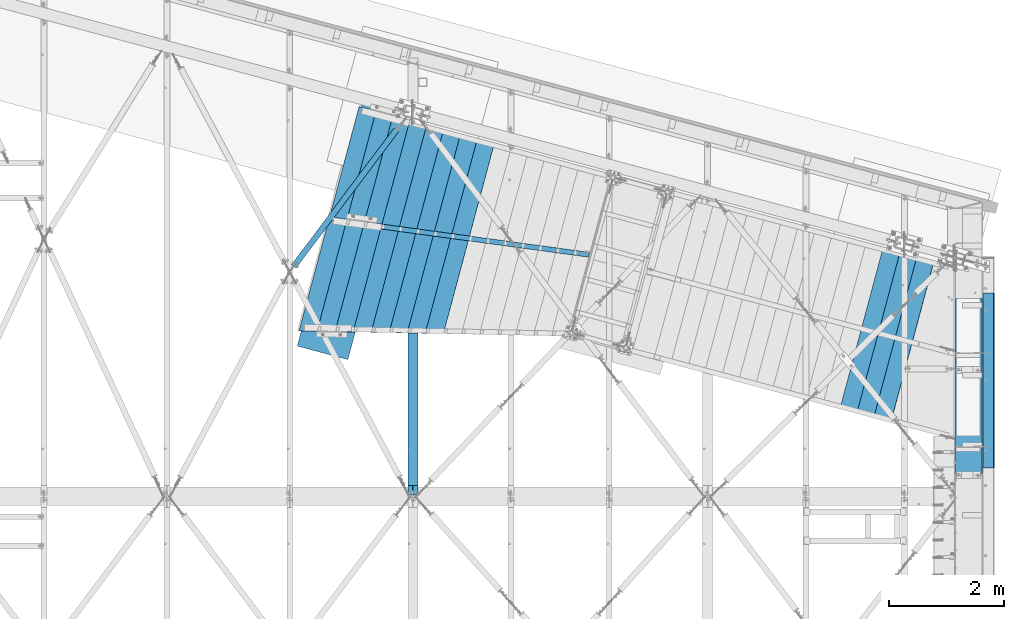
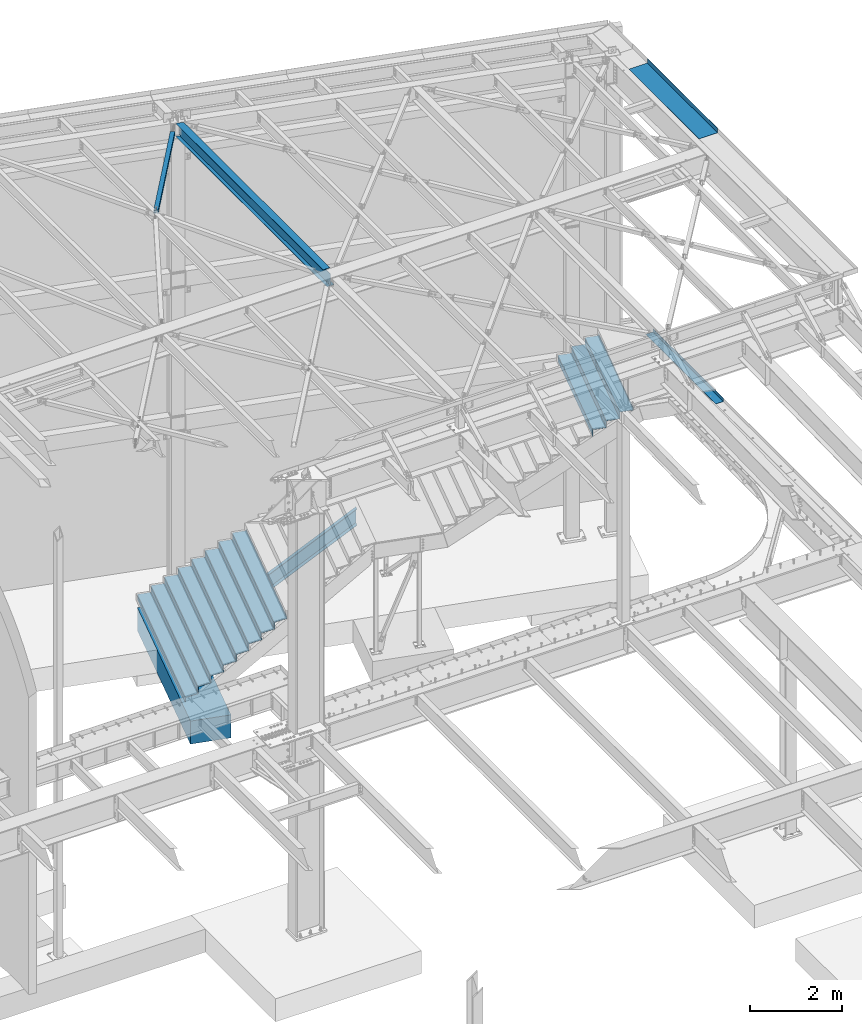
# One storey, part 1171 of 1763: 16 beams, 1 member, 7 elements without a shape of their own.
"""IFC2X3 building model written with IfcOpenShell, lengths in millimetres."""

from ifc_helpers import new_model, si_unit, frame, origin_with_axes, place, context, subcontext, project, spatial, faceted_brep, material, type_object, element, aggregate, save


model = new_model("IFC2X3")

# Units and contexts
model_context = context("Model", 3, precision=1e-05, world=origin_with_axes())
body_context = subcontext(model_context, "Body", "Model", "MODEL_VIEW")
ifc_project = project(units=[si_unit("LENGTHUNIT", "METRE", prefix="MILLI"), si_unit("AREAUNIT", "SQUARE_METRE"), si_unit("VOLUMEUNIT", "CUBIC_METRE"), si_unit("MASSUNIT", "GRAM", prefix="KILO"), si_unit("TIMEUNIT", "SECOND"), si_unit("PLANEANGLEUNIT", "RADIAN"), si_unit("SOLIDANGLEUNIT", "STERADIAN"), si_unit("THERMODYNAMICTEMPERATUREUNIT", "DEGREE_CELSIUS"), si_unit("LUMINOUSINTENSITYUNIT", "LUMEN")], contexts=[model_context])

# Site, building, storey
site_placement = place(None, origin_with_axes())
site = spatial("IfcSite", under=ifc_project, at=site_placement, CompositionType="ELEMENT")
building_placement = place(site_placement, origin_with_axes())
building = spatial("IfcBuilding", under=site, at=building_placement, Name="Undefined", CompositionType="ELEMENT")
storey_placement = place(building_placement, origin_with_axes())
storey = spatial("IfcBuildingStorey", under=building, at=storey_placement, Name="Undefined", CompositionType="ELEMENT", Elevation=0.0)

# Assembly, beam
assembly_1_placement = place(storey_placement, origin_with_axes())
assembly_1 = element("IfcElementAssembly", 1, at=assembly_1_placement, inside=storey, Name="BEAM", AssemblyPlace="NOTDEFINED", PredefinedType="RIGID_FRAME")
ifc_material_1 = material(Name="STEEL/A992")
beam_type_1 = type_object("IfcBeamType", Name="W14X30", PredefinedType="NOTDEFINED")
beam_1_placement = place(assembly_1_placement, frame((-31109.3096174484, 57702.4500000007, 12269.7875), z_axis=(0.0, 0.0, 1.0), x_axis=(0.0, 1.0, 0.0)))
beam_1 = element("IfcBeam", 2, at=beam_1_placement, type_object=beam_type_1, material=ifc_material_1, Name="BEAM", ObjectType="W14X30", context=body_context, shape_type="Brep", body=[
    faceted_brep([(6565.47208704926, 3.17499999999927, -166.6875), (6545.74981877552, 3.17499999999927, -166.6875), (6544.04801117296, -3.17499999999927, -166.6875), (6563.7702794467, -3.17499999999927, -166.6875), (6529.72406312962, 3.17499999999927, -155.679724431486), (6528.02225552706, -3.17499999999927, -155.679724427036), (6526.36654579163, 3.17499999999927, -152.226204529208), (6524.66473818907, -3.17499999999927, -152.226204524761), (6525.14678965067, 3.17499999999927, -147.637500862207), (6523.44498204811, -3.17499999999927, -147.637500857758), (6526.36654603869, 3.17499999999927, -143.048797256899), (6524.66473843613, -3.17499999999927, -143.048797252452), (6529.72406356262, 3.17499999999927, -139.595277524442), (6528.02225596006, -3.17499999999927, -139.595277519993), (6535.00792532179, 3.17499999999927, -138.112501016223), (6533.30611771923, -3.17499999999927, -138.112501011774), (6567.87837071862, 3.17499999999927, -138.11250011349), (6566.17656311606, -3.17499999999927, -138.112500109051), (192.087499999572, 85.7249999999985, 176.2125), (192.087499999572, -85.7249999999985, 176.2125), (6541.64678061339, -85.7249999999985, 176.2125), (6587.59558588255, 85.7249999999985, 176.2125), (6567.87331845542, 85.7249999999985, 166.6875), (192.087499999572, 85.7249999999985, 166.6875), (6593.28891422421, 85.7249999999985, 166.6875), (6545.74981962212, 3.17499999999927, 166.6875), (192.087499999572, 3.17499999999927, 166.6875), (6571.1654153411, 3.17500001334702, 166.687500583917), (20.6374999995751, 85.7249999999985, -176.2125), (20.6374999995751, 85.7249999999985, -166.6875), (6567.87331760882, 85.7249999999985, -166.6875), (6587.59558588256, 85.7249999999985, -166.6875), (6593.2889142238, 85.7249999984415, -176.21249961853), (20.6374999995751, -85.7249999999985, -176.2125), (6547.34010894869, -85.7249999999985, -176.2125), (20.6374999995751, -85.7249999999985, -166.6875), (6541.6467806134, -85.7249999999985, -166.6875), (20.6374999995751, 3.17499999999927, -166.6875), (20.6374999995751, -3.17499999999927, -166.6875), (20.6374999995751, -3.17499999999927, 137.852501678466), (20.6374999995751, 3.17499999999927, 137.852501678466), (179.387500190307, -3.17499999999927, 137.852501678466), (179.387500190307, 3.17499999999927, 137.852501678466), (184.247579708353, -3.17499999999927, 138.819231601054), (184.247579708353, 3.17499999999927, 138.819231601054), (188.367756176507, -3.17499999999927, 141.572245501531), (188.367756176507, 3.17499999999927, 141.572245501531), (191.120770076981, -3.17499999999927, 145.692421969685), (191.120770076981, 3.17499999999927, 145.692421969685), (192.087499999572, -3.17499999999927, 150.552501487731), (192.087499999572, 3.17499999999927, 150.552501487731), (192.087499999572, -3.17499999999927, 166.6875), (192.087499999572, -85.7249999999985, 166.6875), (6547.34010895504, -85.7249999999985, 166.6875), (6552.64892557845, -65.9160712421944, 166.6875), (6569.46360778834, -3.17499999999927, 166.6875), (6544.04801201956, -3.17499999999927, 166.6875), (6528.02225637366, -3.17499999999927, 155.679724224736), (6529.72406397622, 3.17499999999927, 155.679724229183), (6524.66473903567, -3.17499999999927, 152.226204322458), (6526.36654663823, 3.17499999999927, 152.226204326907), (6523.44498289471, -3.17499999999927, 147.637500655457), (6525.14679049727, 3.17499999999927, 147.637500659905), (6524.66473928273, -3.17499999999927, 143.048797050149), (6526.36654688529, 3.17499999999927, 143.048797054596), (6528.02225680666, -3.17499999999927, 139.595277317692), (6529.72406440922, 3.17499999999927, 139.59527732214), (6533.30611856584, -3.17499999999927, 138.112500809471), (6535.00792616839, 3.17499999999927, 138.112500813921), (6566.17656311627, -3.17499999999927, 138.112499906796), (6567.87837071883, 3.17499999999927, 138.112500230807), (6556.74970438206, -29.3710585869703, -166.6875)], [[[0, 1, 2, 3]], [[4, 5, 2, 1]], [[6, 7, 5, 4]], [[8, 9, 7, 6]], [[10, 11, 9, 8]], [[12, 13, 11, 10]], [[14, 15, 13, 12]], [[16, 17, 15, 14]], [[18, 19, 20, 21]], [[22, 23, 18, 21, 24]], [[25, 26, 23, 22, 24, 27]], [[28, 29, 30, 31, 32]], [[33, 28, 32, 34]], [[35, 33, 34, 36]], [[37, 29, 28, 33, 35, 38, 39, 40]], [[41, 42, 40, 39]], [[43, 44, 42, 41]], [[45, 46, 44, 43]], [[47, 48, 46, 45]], [[49, 50, 48, 47]], [[19, 18, 23, 26, 50, 49, 51, 52]], [[19, 52, 53, 20]], [[24, 21, 20, 53, 54, 55, 27]], [[53, 52, 51, 56, 55, 54]], [[27, 55, 56, 25]], [[25, 56, 57, 58]], [[58, 57, 59, 60]], [[60, 59, 61, 62]], [[62, 61, 63, 64]], [[64, 63, 65, 66]], [[66, 65, 67, 68]], [[68, 67, 69, 70]], [[12, 10, 8, 6, 4, 1, 37, 40, 42, 44, 46, 48, 50, 26, 25, 58, 60, 62, 64, 66, 68, 70, 16, 14]], [[30, 29, 37, 1, 0, 31]], [[71, 36, 34, 32, 31, 0, 3]], [[3, 2, 38, 35, 36, 71]], [[69, 67, 65, 63, 61, 59, 57, 56, 51, 49, 47, 45, 43, 41, 39, 38, 2, 5, 7, 9, 11, 13, 15, 17]], [[70, 69, 17, 16]]]),
])
aggregate(assembly_1, [beam_1])

assembly_2_placement = place(storey_placement, origin_with_axes())
assembly_2 = element("IfcElementAssembly", 3, at=assembly_2_placement, inside=storey, Name="H. BRACE", AssemblyPlace="NOTDEFINED", PredefinedType="RIGID_FRAME")
ifc_material_2 = material()
beam_type_2 = type_object("IfcBeamType", Name="HSS4X4X3/8", PredefinedType="NOTDEFINED")
beam_2_placement = place(assembly_2_placement, frame((-33252.4396171231, 61613.3086276461, 12371.3875), z_axis=(0.0, 0.0, 1.0), x_axis=(0.600727201865072, 0.799454081820439, 0.0)))
beam_2 = element("IfcBeam", 4, at=beam_2_placement, type_object=beam_type_2, material=ifc_material_2, Name="H. BRACE", ObjectType="HSS4X4X3/8", context=body_context, shape_type="Brep", body=[
    faceted_brep([(115.172522804187, 6.34475693275454, 50.7999999999993), (115.172522804187, 6.34475693275454, 41.2749999999996), (192.590787124383, 6.34474658969702, 41.2749999999996), (192.590787124383, 6.34474658969702, 50.7999999999993), (192.590785427663, -6.35525341022003, 50.7999999999993), (192.590785427663, -6.35525341022003, 41.2749999999996), (115.172522804187, -6.35524306716979, 41.2749999999996), (115.172522804187, -6.35524306716979, 50.7999999999993), (115.172522804187, 6.34475693275454, -41.2749999999996), (115.172522804187, 6.34475693275454, -50.7999999999993), (192.590787124383, 6.34474658969702, -50.7999999999993), (192.590787124383, 6.34474658969702, -41.2749999999996), (192.590785427663, -6.35525341022003, -41.2749999999996), (192.590785427663, -6.35525341022003, -50.7999999999993), (115.172522804187, -6.35524306716979, -50.7999999999993), (115.172522804187, -6.35524306716979, -41.2749999999996), (115.172522804194, -41.2749999996449, -41.2749999999996), (115.172522804194, -41.2749999996449, 41.2749999999996), (3100.13752571221, -41.2749999951629, 41.2749999999996), (3100.13752571221, -41.2749999951629, -41.2749999999996), (115.172522804183, 50.7999999999738, -50.7999999999993), (3100.13752571221, 50.8000000044631, -50.7999999999993), (3100.13752571221, -50.799999995128, -50.7999999999993), (115.172522804194, -50.79999999961, -50.7999999999993), (115.172522804194, -50.79999999961, 50.7999999999993), (3100.13752571221, -50.799999995128, 50.7999999999993), (115.172522804187, 41.2750000000087, 41.2749999999996), (3100.13752571221, 41.2750000045053, 41.2749999999996), (115.172522804187, 41.2750000000087, -41.2749999999996), (3100.13752571221, 41.2750000045053, -41.2749999999996), (3100.13752571221, 50.8000000044631, 50.7999999999993), (115.172522804183, 50.7999999999738, 50.7999999999993)], [[[0, 1, 2, 3]], [[4, 5, 6, 7]], [[3, 2, 5, 4]], [[8, 9, 10, 11]], [[12, 13, 14, 15]], [[11, 10, 13, 12]], [[16, 17, 18, 19]], [[9, 20, 21, 22, 23, 14, 13, 10]], [[24, 23, 22, 25]], [[17, 16, 15, 14, 23, 24, 7, 6]], [[1, 26, 27, 18, 17, 6, 5, 2]], [[26, 28, 29, 27]], [[25, 22, 21, 30], [18, 27, 29, 19]], [[20, 31, 30, 21]], [[24, 25, 30, 31, 0, 3, 4, 7]], [[31, 20, 9, 8, 28, 26, 1, 0]], [[16, 19, 29, 28, 8, 11, 12, 15]]]),
])
aggregate(assembly_2, [beam_2])

assembly_3_placement = place(storey_placement, origin_with_axes())
assembly_3 = element("IfcElementAssembly", 5, at=assembly_3_placement, inside=storey, Name="BEAM", AssemblyPlace="NOTDEFINED", PredefinedType="RIGID_FRAME")
ifc_material_3 = material(Name="STEEL/A36")
beam_type_3 = type_object("IfcBeamType", PredefinedType="NOTDEFINED")
beam_3_placement = place(assembly_3_placement, frame((-21657.3396174483, 59620.15, 12449.175), z_axis=(0.0, -1.0, 0.0), x_axis=(1.0, 0.0, 0.0)))
beam_3 = element("IfcBeam", 6, at=beam_3_placement, type_object=beam_type_3, material=ifc_material_3, Name="BENT_PLATE", context=body_context, shape_type="Brep", body=[
    faceted_brep([(0.0, -3.17499999999927, -1523.99999999999), (0.0, -3.17499999999927, 1524.0), (0.0, 3.17499999999927, 1524.0), (0.0, 3.17499999999927, -1523.99999999999), (460.375006103517, 3.17499999999927, 1524.0), (460.375006103517, 3.17499999999927, -1524.0), (466.725006103516, -3.17499999999927, -1524.0), (466.725006103516, -3.17499999999927, 1524.0), (460.375006103517, 123.825000000001, 1524.0), (460.375006103517, 123.825000000001, -1524.0), (466.725006103516, 123.825000000001, 1524.0), (466.725006103516, 123.825000000001, -1524.0)], [[[0, 1, 2, 3]], [[3, 2, 4, 5]], [[1, 0, 6, 7]], [[5, 4, 8, 9]], [[4, 2, 1, 7, 10, 8]], [[7, 6, 11, 10]], [[6, 0, 3, 5, 9, 11]], [[10, 11, 9, 8]]]),
])
aggregate(assembly_3, [beam_3])

# Assembly, member
assembly_4_placement = place(storey_placement, origin_with_axes())
assembly_4 = element("IfcElementAssembly", 7, at=assembly_4_placement, inside=storey, Name="STRINGER", AssemblyPlace="NOTDEFINED", PredefinedType="RIGID_FRAME")
member_type = type_object("IfcMemberType", Name="C15X33.9", PredefinedType="NOTDEFINED")
member_placement = place(assembly_4_placement, frame((-27854.1075451843, 61883.1673124353, 2495.92782182921), z_axis=(0.49628907329289, -0.0674194660398061, -0.865535540188265), x_axis=(-0.857644272703664, 0.116610785959708, -0.500847507826946)))
member = element("IfcMember", 8, at=member_placement, type_object=member_type, material=ifc_material_3, Name="STRINGER", ObjectType="C15X33.9", context=body_context, shape_type="Brep", body=[
    faceted_brep([(117.188553758227, -42.8624999999302, -190.499999999982), (122.242523850124, -42.8624999999083, -181.765892499978), (118.370424609493, 33.3374999998414, -169.070972499943), (314.035439820684, 33.3375000004671, 169.07097250022), (332.599308311685, -42.8624999992462, 181.7658925002), (337.653278403573, -42.8624999992244, 190.5000000002), (325.03304655453, 42.8625000004686, 190.500000000236), (104.568321909188, 42.8624999997701, -190.499999999949), (5293.38068464317, -42.8624999935782, -190.499999997053), (5278.29161672973, -42.8624999935855, -181.76589249706), (5256.36493450026, 33.3375000061424, -169.070972497037), (4672.18998903655, 33.3375000058222, 169.070972502683), (4650.25311450638, -42.862499993942, 181.765892502644), (4635.16404659294, -42.8624999939566, 190.500000002634), (4635.16977976208, 42.8625000057655, 190.50000000267), (5293.38641781232, 42.8625000061365, -190.499999997017)], [[[0, 1, 2, 3, 4, 5, 6, 7]], [[1, 0, 8, 9]], [[2, 1, 9, 10]], [[3, 2, 10, 11]], [[4, 3, 11, 12]], [[5, 4, 12, 13]], [[6, 5, 13, 14]], [[7, 6, 14, 15]], [[0, 7, 15, 8]], [[14, 13, 12, 11, 10, 9, 8, 15]]]),
])

# Assembly, beam
assembly_5_placement = place(storey_placement, origin_with_axes())
assembly_5 = element("IfcElementAssembly", 9, at=assembly_5_placement, inside=storey, Name="BEAM", AssemblyPlace="NOTDEFINED", PredefinedType="RIGID_FRAME")
beam_type_4 = type_object("IfcBeamType", PredefinedType="NOTDEFINED")
beam_4_placement = place(assembly_5_placement, frame((-21181.0896174484, 59717.781, 5199.0625), z_axis=(0.0, -1.0, 0.0), x_axis=(1.0, 0.0, 0.0)))
beam_4 = element("IfcBeam", 10, at=beam_4_placement, type_object=beam_type_4, material=ifc_material_3, Name="BENT PLATE", context=body_context, shape_type="Brep", body=[
    faceted_brep([(0.0, -4.76249999999982, -1524.0), (0.0, -4.76249999999982, 1524.0), (0.0, 4.76249999999982, 1524.0), (0.0, 4.76249999999982, -1524.0), (187.325021362303, 4.76249999999982, 1524.0), (187.325021362303, 4.76249999999982, -1524.0), (196.850021362305, -4.76249999999982, -1524.0), (196.850021362305, -4.76249999999982, 1524.0), (187.325021362303, 84.1374938964846, 1524.0), (187.325021362303, 84.1374938964846, -1524.0), (196.850021362305, 84.1374938964846, 1524.0), (196.850021362305, 84.1374938964846, -1524.0)], [[[0, 1, 2, 3]], [[3, 2, 4, 5]], [[1, 0, 6, 7]], [[5, 4, 8, 9]], [[4, 2, 1, 7, 10, 8]], [[7, 6, 11, 10]], [[6, 0, 3, 5, 9, 11]], [[10, 11, 9, 8]]]),
])
aggregate(assembly_5, [beam_4])

# Assembly, beams
assembly_6_placement = place(storey_placement, origin_with_axes())
assembly_6 = element("IfcElementAssembly", 11, at=assembly_6_placement, inside=storey, Name="STRINGER", AssemblyPlace="NOTDEFINED", PredefinedType="RIGID_FRAME")
beam_type_5 = type_object("IfcBeamType", PredefinedType="NOTDEFINED")
beam_5_placement = place(assembly_6_placement, frame((-22407.9777833315, 60395.309640342, 5175.24994812047), z_axis=(-0.258865912030778, -0.965913267114844, 3.00823476209188e-08), x_axis=(0.0, 0.0, -1.0)))
beam_5 = element("IfcBeam", 12, at=beam_5_placement, type_object=beam_type_5, material=ifc_material_3, Name="BENT_PLATE", context=body_context, shape_type="Brep", body=[
    faceted_brep([(1.9117578631267e-09, -1.5875000009255, -1460.49999999993), (-1.18325260700658e-09, -1.58749999909924, 1460.49999999992), (-1.9117578631267e-09, 1.58750000090367, 1460.49999999991), (1.18234311230481e-09, 1.58749999907741, -1460.49999999993), (50.7999999972071, 1.58750001260341, 1460.50000000007), (50.800000002233, 1.58750001077715, -1460.49999999979), (47.6250000029295, -1.58749998995336, -1460.4999999998), (47.6249999979027, -1.58749998812709, 1460.50000000005), (50.8000000657603, -306.387503397986, 1460.50000000045), (50.8000000687034, -306.387503401733, -1460.49999999939), (47.6250000693999, -309.562503402434, -1460.4999999994), (47.6250000664559, -309.562503398687, 1460.50000000045), (222.250000065187, -306.387503360114, 1460.50000000094), (222.250000068131, -306.387503363934, -1460.49999999891), (222.250000065887, -309.562503360117, 1460.50000000094), (222.250000068831, -309.562503363937, -1460.4999999989)], [[[0, 1, 2, 3]], [[3, 2, 4, 5]], [[1, 0, 6, 7]], [[5, 4, 8, 9]], [[7, 6, 10, 11]], [[9, 8, 12, 13]], [[8, 4, 2, 1, 7, 11, 14, 12]], [[11, 10, 15, 14]], [[10, 6, 0, 3, 5, 9, 13, 15]], [[14, 15, 13, 12]]]),
])
beam_6_placement = place(assembly_6_placement, frame((-22702.3881999739, 60474.2119844862, 4997.44989929234), z_axis=(-0.258865912030778, -0.965913267114844, 3.00823476209188e-08), x_axis=(0.0, 0.0, -1.0)))
beam_6 = element("IfcBeam", 13, at=beam_6_placement, type_object=beam_type_5, material=ifc_material_3, Name="BENT_PLATE", context=body_context, shape_type="Brep", body=[
    faceted_brep([(1.9117578631267e-09, -1.5875000009255, -1460.49999999993), (-1.18325260700658e-09, -1.58749999909924, 1460.49999999992), (-1.9117578631267e-09, 1.58750000090367, 1460.49999999991), (1.18234311230481e-09, 1.58749999907741, -1460.49999999993), (50.7999999972071, 1.58750001260341, 1460.50000000007), (50.800000002233, 1.58750001077715, -1460.49999999979), (47.6250000029295, -1.58749998995336, -1460.4999999998), (47.6249999979027, -1.58749998812709, 1460.50000000005), (50.8000000657603, -306.387503397986, 1460.50000000045), (50.8000000687034, -306.387503401733, -1460.49999999939), (47.6250000693999, -309.562503402434, -1460.4999999994), (47.6250000664559, -309.562503398687, 1460.50000000045), (222.250000065187, -306.387503360114, 1460.50000000094), (222.250000068131, -306.387503363934, -1460.49999999891), (222.250000065887, -309.562503360117, 1460.50000000094), (222.250000068831, -309.562503363937, -1460.4999999989)], [[[0, 1, 2, 3]], [[3, 2, 4, 5]], [[1, 0, 6, 7]], [[5, 4, 8, 9]], [[7, 6, 10, 11]], [[9, 8, 12, 13]], [[8, 4, 2, 1, 7, 11, 14, 12]], [[11, 10, 15, 14]], [[10, 6, 0, 3, 5, 9, 13, 15]], [[14, 15, 13, 12]]]),
])
beam_7_placement = place(assembly_6_placement, frame((-22996.7985860936, 60553.1143204503, 4819.65009460484), z_axis=(-0.258865912030778, -0.965913267114844, 3.00823476209188e-08), x_axis=(0.0, 0.0, -1.0)))
beam_7 = element("IfcBeam", 14, at=beam_7_placement, type_object=beam_type_5, material=ifc_material_3, Name="BENT_PLATE", context=body_context, shape_type="Brep", body=[
    faceted_brep([(1.9117578631267e-09, -1.5875000009255, -1460.49999999993), (-1.18325260700658e-09, -1.58749999909924, 1460.49999999992), (-1.9117578631267e-09, 1.58750000090367, 1460.49999999991), (1.18234311230481e-09, 1.58749999907741, -1460.49999999993), (50.7999999972071, 1.58750001260341, 1460.50000000007), (50.800000002233, 1.58750001077715, -1460.49999999979), (47.6250000029295, -1.58749998995336, -1460.4999999998), (47.6249999979027, -1.58749998812709, 1460.50000000005), (50.8000000657603, -306.387503397986, 1460.50000000045), (50.8000000687034, -306.387503401733, -1460.49999999939), (47.6250000693999, -309.562503402434, -1460.4999999994), (47.6250000664559, -309.562503398687, 1460.50000000045), (222.250000065187, -306.387503360114, 1460.50000000094), (222.250000068131, -306.387503363934, -1460.49999999891), (222.250000065887, -309.562503360117, 1460.50000000094), (222.250000068831, -309.562503363937, -1460.4999999989)], [[[0, 1, 2, 3]], [[3, 2, 4, 5]], [[1, 0, 6, 7]], [[5, 4, 8, 9]], [[7, 6, 10, 11]], [[9, 8, 12, 13]], [[8, 4, 2, 1, 7, 11, 14, 12]], [[11, 10, 15, 14]], [[10, 6, 0, 3, 5, 9, 13, 15]], [[14, 15, 13, 12]]]),
])
aggregate(assembly_6, [beam_5, beam_6, beam_7])

# Beam
beam_8_placement = place(assembly_4_placement, frame((-31964.6397371048, 62414.0763199668, 374.650096866085), z_axis=(-0.258865912030778, -0.965913267114844, 3.00823476209188e-08), x_axis=(0.0, 0.0, -1.0)))
beam_8 = element("IfcBeam", 15, at=beam_8_placement, type_object=beam_type_5, material=ifc_material_3, Name="BENT_PLATE", context=body_context, shape_type="Brep", body=[
    faceted_brep([(47.6250006177821, -309.562503402703, -1984.37499999935), (47.6250005516575, -1.58749999016436, -1984.37499999975), (2.53851339948596e-09, -1.58750000123837, -1984.3749999999), (1.80216375156306e-09, 1.58749999876454, -1984.37499999991), (50.8000005509619, 1.58750001057342, -1984.37499999975), (50.8000006170864, -306.387503402002, -1984.37499999934), (222.250000064546, -306.387503364487, -1984.37499999885), (222.250000065245, -309.56250336449, -1984.37499999884), (222.250000061582, -309.562503359295, 1984.37500000095), (47.6250006133301, -309.562503398163, 1984.37500000044), (47.6250005446408, -1.58749998772691, 1908.41890732066), (-1.71917236002628e-09, -1.58749999880092, 1908.41890875338), (-2.45466935666627e-09, 1.58750000119471, 1907.63422931232), (50.8000005439466, 1.58750001301087, 1907.6342277841), (50.8000006126352, -306.387503397462, 1983.74813440931), (222.250000060884, -306.387503359299, 1983.74812925194)], [[[0, 1, 2, 3, 4, 5, 6, 7]], [[0, 7, 8, 9]], [[1, 0, 9, 10]], [[2, 1, 10, 11]], [[3, 2, 11, 12]], [[4, 3, 12, 13]], [[5, 4, 13, 14]], [[6, 5, 14, 15]], [[7, 6, 15, 8]], [[14, 13, 12, 11, 10, 9, 8, 15]]]),
])

beam_9_placement = place(assembly_4_placement, frame((-30139.6173198625, 62159.1697957013, 1441.45007779072), z_axis=(-0.258865912030778, -0.965913267114844, 3.00823476209188e-08), x_axis=(0.0, 0.0, -1.0)))
beam_9 = element("IfcBeam", 16, at=beam_9_placement, type_object=beam_type_5, material=ifc_material_3, Name="BENT_PLATE", context=body_context, shape_type="Brep", body=[
    faceted_brep([(47.6250005522106, -309.562503398098, 1758.15650000044), (47.6250005557556, -309.562503402907, -1758.15649999938), (222.250000066033, -309.562503364272, -1758.15649999886), (222.250000062288, -309.562503359673, 1758.15650000095), (47.6250004894098, -1.5874999900625, -1758.15649999978), (2.10025064006913e-09, -1.5875000011074, -1758.15649999991), (1.36583366838749e-09, 1.58749999889551, -1758.15649999992), (50.800000488714, 1.58750001067529, -1758.15649999977), (50.8000005550598, -306.387503402206, -1758.15649999937), (222.250000065334, -306.387503364276, -1758.15649999888), (222.250000061589, -306.387503359671, 1758.15650000094), (50.8000005515146, -306.387503397396, 1758.15650000044), (47.6250005516536, -307.064026991226, 1758.15650000044), (47.6250004836606, -1.58749998790881, 1682.65967686754), (-1.291709850193e-09, -1.58749999895372, 1682.65967830025), (-2.02544470084831e-09, 1.58750000104192, 1681.87499472473), (50.800000482966, 1.58750001282897, 1681.8749931965)], [[[0, 1, 2, 3]], [[1, 4, 5, 6, 7, 8, 9, 2]], [[3, 2, 9, 10]], [[8, 11, 10, 9]], [[0, 3, 10, 11, 12]], [[4, 1, 0, 12, 13]], [[5, 4, 13, 14]], [[6, 5, 14, 15]], [[7, 6, 15, 16]], [[8, 7, 16, 11]], [[15, 14, 13, 12, 11, 16]]]),
])

beam_10_placement = place(assembly_4_placement, frame((-30443.8904260091, 62201.271154135, 1263.65003011975), z_axis=(-0.258865912030778, -0.965913267114844, 3.00823476209188e-08), x_axis=(0.0, 0.0, -1.0)))
beam_10 = element("IfcBeam", 17, at=beam_10_placement, type_object=beam_type_5, material=ifc_material_3, Name="BENT_PLATE", context=body_context, shape_type="Brep", body=[
    faceted_brep([(47.6250005668378, -309.562503402558, -1796.25599999937), (47.6250005005361, -1.58749999008432, -1796.25599999976), (2.40311237575952e-09, -1.58750000112923, -1796.25599999991), (1.66892277775332e-09, 1.58749999887368, -1796.25599999991), (50.8000004998401, 1.58750001064618, -1796.25599999975), (50.8000005661418, -306.387503401857, -1796.25599999937), (222.250000065152, -306.387503364313, -1796.25599999889), (222.250000065851, -309.562503364308, -1796.25599999887), (222.250000062331, -309.562503359608, 1796.25600000093), (47.6250005628074, -309.56250339844, 1796.25600000044), (47.6250004942242, -1.58749998788699, 1719.8896347092), (-1.58297552843578e-09, -1.58749999893189, 1719.88963614191), (-2.3162556317402e-09, 1.58750000107102, 1719.10495256639), (50.8000004935298, 1.5875000128508, 1719.10495103816), (50.8000005621125, -306.387503397738, 1795.21925870668), (222.250000061633, -306.387503359612, 1795.21925354933)], [[[0, 1, 2, 3, 4, 5, 6, 7]], [[0, 7, 8, 9]], [[1, 0, 9, 10]], [[2, 1, 10, 11]], [[3, 2, 11, 12]], [[4, 3, 12, 13]], [[5, 4, 13, 14]], [[6, 5, 14, 15]], [[7, 6, 15, 8]], [[14, 13, 12, 11, 10, 9, 8, 15]]]),
])

beam_11_placement = place(assembly_4_placement, frame((-30747.9580364353, 62244.138785377, 1085.85010449534), z_axis=(-0.258865912030778, -0.965913267114844, 3.00823476209188e-08), x_axis=(0.0, 0.0, -1.0)))
beam_11 = element("IfcBeam", 18, at=beam_11_placement, type_object=beam_type_5, material=ifc_material_3, Name="BENT_PLATE", context=body_context, shape_type="Brep", body=[
    faceted_brep([(47.6250005776251, -309.562503402944, -1833.56249999938), (47.6250005113077, -1.58749999010615, -1833.56249999978), (2.17505657928996e-09, -1.58750000115106, -1833.56249999991), (1.43995748658199e-09, 1.58749999884458, -1833.56249999992), (50.8000005106119, 1.58750001063163, -1833.56249999977), (50.8000005769293, -306.387503402242, -1833.56249999938), (222.250000065225, -306.387503364364, -1833.56249999888), (222.250000065924, -309.562503364366, -1833.56249999887), (47.6250005739282, -309.562503398047, 1833.56250000043), (222.250000062123, -309.562503359564, 1833.56250000094), (222.250000061709, -307.682177941264, 1833.56250000093), (47.6250005735087, -307.682156723829, 1833.56250000043), (47.6250005053491, -1.58749998785061, 1757.91290954509), (-1.36537892103661e-09, -1.58749999890279, 1757.9129109778), (-2.09979589271825e-09, 1.58750000110012, 1757.12822740227), (50.8000005046545, 1.5875000128799, 1757.12822587405), (50.8000005732322, -306.387503397345, 1833.24253354249), (222.250000061424, -306.387503359569, 1833.24252838521)], [[[0, 1, 2, 3, 4, 5, 6, 7]], [[8, 0, 7, 9]], [[8, 9, 10, 11]], [[1, 0, 8, 11, 12]], [[2, 1, 12, 13]], [[3, 2, 13, 14]], [[4, 3, 14, 15]], [[5, 4, 15, 16]], [[6, 5, 16, 17]], [[9, 7, 6, 17, 10]], [[16, 15, 14, 13, 12, 11, 10, 17]]]),
])

beam_12_placement = place(assembly_4_placement, frame((-31052.2312332983, 62286.2398358356, 908.050056823313), z_axis=(-0.258865912030778, -0.965913267114844, 3.00823476209188e-08), x_axis=(0.0, 0.0, -1.0)))
beam_12 = element("IfcBeam", 19, at=beam_12_placement, type_object=beam_type_5, material=ifc_material_3, Name="BENT_PLATE", context=body_context, shape_type="Brep", body=[
    faceted_brep([(47.6250005866384, -309.562503403075, -1871.66249999937), (47.6250005204768, -1.58749999013526, -1871.66249999978), (1.99884198082145e-09, -1.58750000116561, -1871.66249999991), (1.26510713016614e-09, 1.5874999988373, -1871.66249999992), (50.8000005197817, 1.58750001060253, -1871.66249999977), (50.8000005859433, -306.38750340238, -1871.66249999936), (222.250000064754, -306.387503364356, -1871.66249999886), (222.250000065453, -309.562503364345, -1871.66249999886), (222.250000061786, -309.562503359455, 1871.2568507941), (47.6250005832908, -309.562503397829, 1871.25685604685), (47.6250005147239, -1.58749998784333, 1795.14254837847), (-1.19848664326128e-09, -1.58749999887368, 1795.14254981118), (-1.93153937289026e-09, 1.58750000112195, 1794.35786623566), (50.8000005140301, 1.58750001289445, 1794.35786470743), (50.8000005825963, -306.387503397134, 1870.47217237583), (222.250000061088, -306.387503359452, 1870.47216721858)], [[[0, 1, 2, 3, 4, 5, 6, 7]], [[0, 7, 8, 9]], [[1, 0, 9, 10]], [[2, 1, 10, 11]], [[3, 2, 11, 12]], [[4, 3, 12, 13]], [[5, 4, 13, 14]], [[6, 5, 14, 15]], [[7, 6, 15, 8]], [[14, 13, 12, 11, 10, 9, 8, 15]]]),
])

beam_13_placement = place(assembly_4_placement, frame((-31356.2990123078, 62329.1073304604, 730.250070162999), z_axis=(-0.258865912030778, -0.965913267114844, 3.00823476209188e-08), x_axis=(0.0, 0.0, -1.0)))
beam_13 = element("IfcBeam", 20, at=beam_13_placement, type_object=beam_type_5, material=ifc_material_3, Name="BENT_PLATE", context=body_context, shape_type="Brep", body=[
    faceted_brep([(47.6250005968396, -309.562503403213, -1908.96899999936), (47.625000530726, -1.58749999017164, -1908.96899999976), (2.03101535589667e-09, -1.58750000119471, -1908.9689999999), (1.29773525259225e-09, 1.5874999988082, -1908.96899999991), (50.8000005300308, 1.58750001057342, -1908.96899999976), (50.8000005961445, -306.387503402511, -1908.96899999935), (222.250000064772, -306.387503364422, -1908.96899999885), (222.250000065471, -309.562503364417, -1908.96899999884), (47.6250005934249, -309.562503397741, 1908.96900000045), (222.250000061622, -309.562503359426, 1908.96900000097), (222.250000061345, -308.304204606473, 1908.96900000096), (47.6250005931441, -308.304183388987, 1908.96900000045), (47.6250005248106, -1.58749998782878, 1833.16567911748), (-1.23202426038915e-09, -1.58749999885913, 1833.16568055018), (-1.96450855582952e-09, 1.58750000114378, 1832.38099697466), (50.8000005241169, 1.587500012909, 1832.38099544644), (50.8000005927303, -306.38750339704, 1908.49530311481), (222.250000060924, -306.387503359423, 1908.49529795758)], [[[0, 1, 2, 3, 4, 5, 6, 7]], [[8, 0, 7, 9]], [[8, 9, 10, 11]], [[1, 0, 8, 11, 12]], [[2, 1, 12, 13]], [[3, 2, 13, 14]], [[4, 3, 14, 15]], [[5, 4, 15, 16]], [[6, 5, 16, 17]], [[9, 7, 6, 17, 10]], [[16, 15, 14, 13, 12, 11, 10, 17]]]),
])

beam_14_placement = place(assembly_4_placement, frame((-31660.5720150403, 62371.2088406032, 552.450083526412), z_axis=(-0.258865912030778, -0.965913267114844, 3.00823476209188e-08), x_axis=(0.0, 0.0, -1.0)))
beam_14 = element("IfcBeam", 21, at=beam_14_placement, type_object=beam_type_5, material=ifc_material_3, Name="BENT_PLATE", context=body_context, shape_type="Brep", body=[
    faceted_brep([(47.6250006071314, -309.562503402885, -1947.06849999935), (47.6250005410873, -1.58749999018619, -1947.06849999976), (2.3525217329734e-09, -1.58750000121654, -1947.06849999991), (1.61878688231809e-09, 1.58749999878637, -1947.06849999991), (50.8000005403922, 1.58750001055159, -1947.06849999976), (50.8000006064363, -306.387503402184, -1947.06849999935), (222.250000064571, -306.387503364451, -1947.06849999884), (222.25000006527, -309.562503364454, -1947.06849999885), (222.250000061677, -309.562503359368, 1946.51022058973), (47.6250006032065, -309.562503398032, 1946.51022584253), (47.6250005345337, -1.5874999877924, 1870.39579691483), (-1.54057033796562e-09, -1.58749999883003, 1870.39579834754), (-2.27350938075688e-09, 1.58750000117288, 1869.61111352192), (50.80000053384, 1.58750001293811, 1869.61111199371), (50.8000006025121, -306.387503397338, 1945.7255409214), (222.250000060979, -306.387503359358, 1945.72553576411)], [[[0, 1, 2, 3, 4, 5, 6, 7]], [[0, 7, 8, 9]], [[1, 0, 9, 10]], [[2, 1, 10, 11]], [[3, 2, 11, 12]], [[4, 3, 12, 13]], [[5, 4, 13, 14]], [[6, 5, 14, 15]], [[7, 6, 15, 8]], [[14, 13, 12, 11, 10, 9, 8, 15]]]),
])

# Assembly, beam
assembly_7_placement = place(storey_placement, origin_with_axes())
assembly_7 = element("IfcElementAssembly", 22, at=assembly_7_placement, inside=storey, Name="FOOTING", AssemblyPlace="NOTDEFINED", PredefinedType="REINFORCEMENT_UNIT")
ifc_material_4 = material(Name="CONCRETE/3000")
beam_type_6 = type_object("IfcBeamType", PredefinedType="NOTDEFINED")
beam_15_placement = place(assembly_7_placement, frame((-31529.0141692477, 64499.41849024, -609.599999999999), z_axis=(0.0, 0.0, 1.0), x_axis=(-0.258865912030778, -0.965913267114844, 3.00823476209188e-08)))
beam_15 = element("IfcBeam", 23, at=beam_15_placement, type_object=beam_type_6, material=ifc_material_4, Name="FOOTING", context=body_context, shape_type="Brep", body=[
    faceted_brep([(-2.83762346953154e-10, 457.199999999983, -304.8), (-2.83762346953154e-10, 457.199999999983, 304.8), (4451.34999999854, 457.200000002769, 304.8), (4451.34999999854, 457.200000002769, -304.8), (2.91038304567337e-10, -457.199999999975, 304.8), (4451.34999999912, -457.199999997181, 304.8), (2.91038304567337e-10, -457.199999999975, -304.8), (4451.34999999912, -457.199999997181, -304.8)], [[[0, 1, 2, 3]], [[1, 4, 5, 2]], [[4, 6, 7, 5]], [[6, 0, 3, 7]], [[5, 7, 3, 2]], [[6, 4, 1, 0]]]),
])
aggregate(assembly_7, [beam_15])

# Beam
beam_type_7 = type_object("IfcBeamType", PredefinedType="NOTDEFINED")
beam_16_placement = place(assembly_4_placement, frame((-32268.9128923133, 62456.1773533287, 196.850079748935), z_axis=(-0.258865912030778, -0.965913267114844, 3.00823476209188e-08), x_axis=(0.0, 0.0, -1.0)))
beam_16 = element("IfcBeam", 24, at=beam_16_placement, type_object=beam_type_7, material=ifc_material_3, Name="BENT_PLATE", context=body_context, shape_type="Brep", body=[
    faceted_brep([(47.6250006605334, -309.562503402929, -2022.47499999939), (47.6250005943563, -1.58749998975691, -2022.47499999976), (2.29744046009728e-09, -1.5875000012602, -2022.4749999999), (1.53252699419681e-09, 1.58749999873544, -2022.4749999999), (50.8000005936609, 1.5875000110027, -2022.47499999975), (50.800000659838, -306.387503402228, -2022.47499999938), (187.325012271568, -306.387503371989, -2022.47499999899), (187.325012272267, -309.562503371992, -2022.47499999899), (187.325012268531, -309.562503367153, 2021.76283698631), (47.6250006569124, -309.562503397909, 2021.76284118852), (47.6250005883022, -1.58749998727581, 1945.64853351998), (-1.45979583976441e-09, -1.58749999878637, 1945.64853495282), (-2.22399876292911e-09, 1.58750000121654, 1944.86385137729), (50.800000587608, 1.5875000134838, 1944.86384984894), (50.8000006562177, -306.387503397207, 2020.9781575175), (187.325012267833, -306.387503367157, 2020.97815341079)], [[[0, 1, 2, 3, 4, 5, 6, 7]], [[0, 7, 8, 9]], [[1, 0, 9, 10]], [[2, 1, 10, 11]], [[3, 2, 11, 12]], [[4, 3, 12, 13]], [[5, 4, 13, 14]], [[6, 5, 14, 15]], [[7, 6, 15, 8]], [[14, 13, 12, 11, 10, 9, 8, 15]]]),
])

aggregate(assembly_4, [member, beam_16, beam_8, beam_9, beam_10, beam_11, beam_12, beam_13, beam_14])

save(model, "model.ifc")
